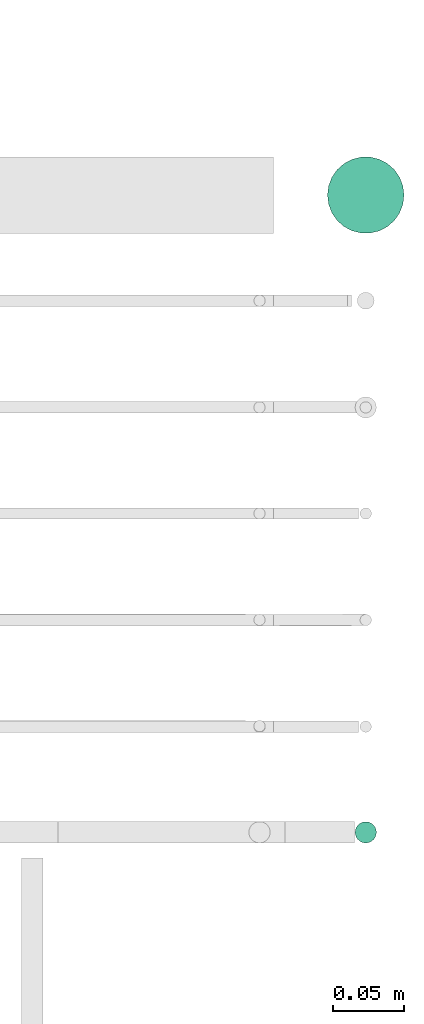
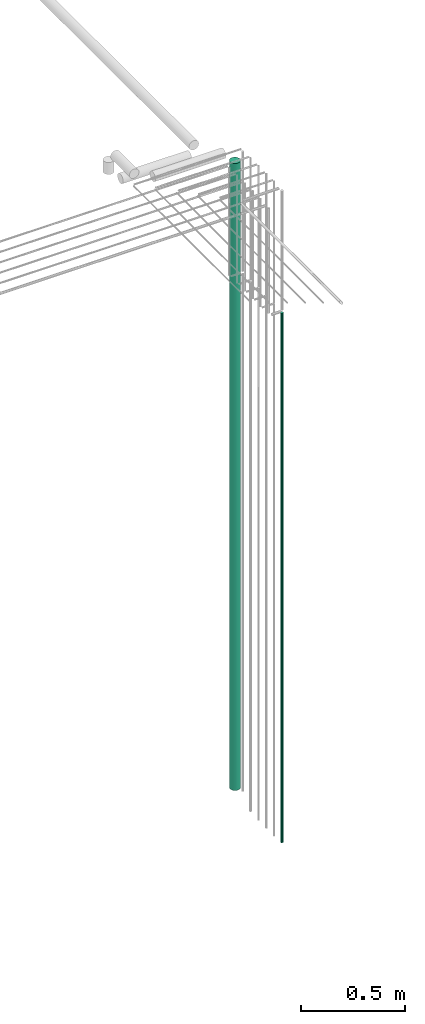
# One storey, part 35 of 89: 2 flow segments.
"""IFC2X3 building model written with IfcOpenShell, lengths in millimetres."""

import ifcopenshell
import ifcopenshell.guid

model = None  # the IFC model being written
_history = None  # IfcOwnerHistory: only IFC2X3 demands one
_inside = {}  # id of a spatial element -> (the spatial element, [elements in it])
_under = {}  # id of a project, library or spatial element -> (it, [spatial elements below it])
_declared = {}  # id of a project -> (the project, [libraries it declares])
_typed = {}  # id of a type object -> (the type object, [elements of that type])
_made_of = {}  # id of a material, layer set ... -> (it, [elements and type objects made of it])


def new_model(schema):
    """Start an empty IFC model of exactly this schema.

    Asked for "IFC4X3", IfcOpenShell would pick the latest addendum, in which some entities
    have other attributes; the version numbers below select the first issue.
    IFC2X3 requires an IfcOwnerHistory on every rooted entity: one is made here for all.
    """
    global model, _history
    if schema == "IFC4X3":
        model = ifcopenshell.file(schema_version=(4, 3, 0, 0))
    else:
        model = ifcopenshell.file(schema=schema)
    _inside.clear()
    _under.clear()
    _declared.clear()
    _typed.clear()
    _made_of.clear()
    _history = None
    if model.schema == "IFC2X3":
        org = make("IfcOrganization", Name="unknown")
        user = make(
            "IfcPersonAndOrganization",
            ThePerson=make("IfcPerson", FamilyName="unknown"),
            TheOrganization=org,
        )
        app = make(
            "IfcApplication",
            ApplicationDeveloper=org,
            Version="unknown",
            ApplicationFullName="unknown",
            ApplicationIdentifier="unknown",
        )
        _history = make(
            "IfcOwnerHistory",
            OwningUser=user,
            OwningApplication=app,
            ChangeAction="ADDED",
            CreationDate=0,
        )
    return model


def make(cls, **values):
    """One entity of the class cls with the attributes given. An attribute that is None is left unset."""
    return model.create_entity(
        cls, **{name: value for name, value in values.items() if value is not None}
    )


def entity(cls, *values):
    """Any entity or typed value of the class cls, its attributes in the order of the schema. None: left unset."""
    e = model.create_entity(cls)
    for i, value in enumerate(values):
        if value is not None:
            e[i] = value
    return e


def rooted(cls, **values):
    """An entity with a GlobalId (a new one), such as an element, a storey or a relation."""
    return make(cls, GlobalId=ifcopenshell.guid.new(), OwnerHistory=_history, **values)


def si_unit(unit_type, name, prefix=None):
    """IfcSIUnit, for example si_unit("LENGTHUNIT", "METRE", prefix="MILLI")."""
    return make("IfcSIUnit", UnitType=unit_type, Prefix=prefix, Name=name)


def converted_unit(unit_type, name, factor, base, dimensions=None, offset=None):
    """IfcConversionBasedUnit, such as the inch: factor (a typed value) times the base unit."""
    return make(
        "IfcConversionBasedUnit"
        if offset is None
        else "IfcConversionBasedUnitWithOffset",
        ConversionOffset=offset,
        Dimensions=None
        if dimensions is None
        else entity("IfcDimensionalExponents", *dimensions),
        UnitType=unit_type,
        Name=name,
        ConversionFactor=make(
            "IfcMeasureWithUnit", ValueComponent=factor, UnitComponent=base
        ),
    )


def derived_unit(unit_type, elements):
    """IfcDerivedUnit: a product of units, each with its exponent."""
    return make(
        "IfcDerivedUnit",
        Elements=[
            make("IfcDerivedUnitElement", Unit=unit, Exponent=power)
            for unit, power in elements
        ],
        UnitType=unit_type,
    )


def assignment(units):
    """IfcUnitAssignment: the units of a project."""
    return None if units is None else make("IfcUnitAssignment", Units=units)


def point(xyz):
    """IfcCartesianPoint."""
    return None if xyz is None else make("IfcCartesianPoint", Coordinates=xyz)


def direction(xyz):
    """IfcDirection."""
    return None if xyz is None else make("IfcDirection", DirectionRatios=xyz)


def frame(location, z_axis=None, x_axis=None):
    """IfcAxis2Placement3D, a coordinate frame: its origin and axes. An axis left out is left unset."""
    return make(
        "IfcAxis2Placement3D",
        Location=point(location),
        Axis=direction(z_axis),
        RefDirection=direction(x_axis),
    )


def frame_2d(location, x_axis=None):
    """IfcAxis2Placement2D, a coordinate frame in the plane: its origin and x axis."""
    return make(
        "IfcAxis2Placement2D", Location=point(location), RefDirection=direction(x_axis)
    )


def origin():
    """The frame at (0, 0, 0) with its axes left unset."""
    return frame((0.0, 0.0, 0.0))


def place(relative_to, where):
    """IfcLocalPlacement: puts the frame where relative to a parent placement (None: the world)."""
    return make(
        "IfcLocalPlacement", PlacementRelTo=relative_to, RelativePlacement=where
    )


def context(
    kind, dimensions, precision=None, world=None, true_north=None, identifier=None
):
    """IfcGeometricRepresentationContext, for example the 3D "Model" context."""
    return make(
        "IfcGeometricRepresentationContext",
        ContextIdentifier=identifier,
        ContextType=kind,
        CoordinateSpaceDimension=dimensions,
        Precision=precision,
        WorldCoordinateSystem=world,
        TrueNorth=true_north,
    )


def subcontext(parent, identifier, kind, view, scale=None):
    """IfcGeometricRepresentationSubContext, for example "Body" below "Model"."""
    return make(
        "IfcGeometricRepresentationSubContext",
        ContextIdentifier=identifier,
        ContextType=kind,
        ParentContext=parent,
        TargetScale=scale,
        TargetView=view,
    )


def project(units=None, contexts=None):
    """IfcProject with its units and contexts."""
    return rooted(
        "IfcProject",
        Name="project",
        RepresentationContexts=contexts,
        UnitsInContext=assignment(units),
    )


def spatial(cls, under=None, at=None, **own):
    """A site, building, storey or space (cls), placed at a placement, below another one or the project."""
    s = rooted(cls, ObjectPlacement=at, **own)
    if under is not None:
        _under.setdefault(under.id(), (under, []))[1].append(s)
    return s


def profile(cls, at=None, kind="AREA", **sizes):
    """A parametric profile (cls). Its sizes go by their IFC names, for example OverallWidth=200.0."""
    return make(cls, ProfileType=kind, Position=at, **sizes)


def circle(**sizes):
    """IfcCircleProfileDef."""
    return profile("IfcCircleProfileDef", **sizes)


def extrude(swept, where, along, depth):
    """IfcExtrudedAreaSolid: the profile swept, set in the frame where, extruded along a direction by depth."""
    return make(
        "IfcExtrudedAreaSolid",
        SweptArea=swept,
        Position=where,
        ExtrudedDirection=direction(along),
        Depth=depth,
    )


def shape(context_of_items, identifier, shape_type, items):
    """IfcShapeRepresentation: the items that make up one representation, for example the "Body"."""
    return make(
        "IfcShapeRepresentation",
        ContextOfItems=context_of_items,
        RepresentationIdentifier=identifier,
        RepresentationType=shape_type,
        Items=items,
    )


def made_of(thing, what):
    """Note that an element or type object is made of a material, layer set ...; save() writes the relation."""
    if what is not None:
        _made_of.setdefault(what.id(), (what, []))[1].append(thing)
    return thing


def type_object(cls, material=None, **own):
    """A type object (cls), such as IfcWallType, which elements share."""
    return made_of(rooted(cls, **own), material)


def element(
    cls,
    number,
    at=None,
    inside=None,
    cuts=None,
    type_object=None,
    material=None,
    context=None,
    identifier="Body",
    shape_type=None,
    held_by="IfcProductDefinitionShape",
    body=None,
    shapes=None,
    **own,
):
    """One element of the class cls, such as IfcWall. Its Tag is "e" and its number.

    at: its placement. inside: the storey or other place that contains it. cuts: it is an
    opening in that element (IfcRelVoidsElement). A single representation is given by context,
    identifier, shape_type and body (its items); several are given by shapes. held_by: the class
    of the entity that holds the representations. save() writes the other relations.
    """
    e = rooted(cls, Tag="e%d" % number, ObjectPlacement=at, **own)
    if body is not None:
        shapes = [shape(context, identifier, shape_type, body)]
    if shapes is not None:
        e.Representation = make(held_by, Representations=shapes)
    if inside is not None:
        _inside.setdefault(inside.id(), (inside, []))[1].append(e)
    if cuts is not None:
        rooted(
            "IfcRelVoidsElement", RelatingBuildingElement=cuts, RelatedOpeningElement=e
        )
    if type_object is not None:
        _typed.setdefault(type_object.id(), (type_object, []))[1].append(e)
    return made_of(e, material)


def aggregate(whole, parts):
    """IfcRelAggregates: a whole, such as a stair, and the parts it consists of."""
    return rooted("IfcRelAggregates", RelatingObject=whole, RelatedObjects=parts)


def save(model, path):
    """Write the relations noted so far, then the file.

    IfcRelAggregates (storeys below a building ...), IfcRelContainedInSpatialStructure (elements
    in a storey), IfcRelDefinesByType, IfcRelAssociatesMaterial and IfcRelDeclares: one each for
    every whole, place, type object, material and project.
    """
    for whole, parts in _under.values():
        aggregate(whole, parts)
    for where, things in _inside.values():
        rooted(
            "IfcRelContainedInSpatialStructure",
            RelatedElements=things,
            RelatingStructure=where,
        )
    for kind, things in _typed.values():
        rooted("IfcRelDefinesByType", RelatedObjects=things, RelatingType=kind)
    for what, things in _made_of.values():
        rooted("IfcRelAssociatesMaterial", RelatedObjects=things, RelatingMaterial=what)
    for by, libraries in _declared.values():
        rooted("IfcRelDeclares", RelatingContext=by, RelatedDefinitions=libraries)
    model.write(path)


model = new_model("IFC2X3")

# Units and contexts
model_context = context("Model", 3, precision=0.01, world=origin(), true_north=direction((6.12303176911189e-17, 1.0)))
body_context = subcontext(model_context, "Body", "Model", "MODEL_VIEW")
ifc_project = project(units=[si_unit("LENGTHUNIT", "METRE", prefix="MILLI"), si_unit("AREAUNIT", "SQUARE_METRE"), si_unit("VOLUMEUNIT", "CUBIC_METRE"), converted_unit("PLANEANGLEUNIT", "DEGREE", entity("IfcRatioMeasure", 0.0174532925199433), si_unit("PLANEANGLEUNIT", "RADIAN"), dimensions=[0, 0, 0, 0, 0, 0, 0]), si_unit("MASSUNIT", "GRAM", prefix="KILO"), derived_unit("MASSDENSITYUNIT", [(si_unit("MASSUNIT", "GRAM", prefix="KILO"), 1), (si_unit("LENGTHUNIT", "METRE"), -3)]), derived_unit("MOMENTOFINERTIAUNIT", [(si_unit("LENGTHUNIT", "METRE"), 4)]), si_unit("TIMEUNIT", "SECOND"), si_unit("FREQUENCYUNIT", "HERTZ"), si_unit("THERMODYNAMICTEMPERATUREUNIT", "DEGREE_CELSIUS"), derived_unit("THERMALTRANSMITTANCEUNIT", [(si_unit("MASSUNIT", "GRAM", prefix="KILO"), 1), (si_unit("THERMODYNAMICTEMPERATUREUNIT", "KELVIN"), -1), (si_unit("TIMEUNIT", "SECOND"), -3)]), derived_unit("VOLUMETRICFLOWRATEUNIT", [(si_unit("LENGTHUNIT", "METRE"), 3), (si_unit("TIMEUNIT", "SECOND"), -1)]), derived_unit("MASSFLOWRATEUNIT", [(si_unit("MASSUNIT", "GRAM", prefix="KILO"), 1), (si_unit("TIMEUNIT", "SECOND"), -1)]), derived_unit("ROTATIONALFREQUENCYUNIT", [(si_unit("TIMEUNIT", "SECOND"), -1)]), si_unit("ELECTRICCURRENTUNIT", "AMPERE"), si_unit("ELECTRICVOLTAGEUNIT", "VOLT"), si_unit("POWERUNIT", "WATT"), si_unit("FORCEUNIT", "NEWTON", prefix="KILO"), si_unit("ILLUMINANCEUNIT", "LUX"), si_unit("LUMINOUSFLUXUNIT", "LUMEN"), si_unit("LUMINOUSINTENSITYUNIT", "CANDELA"), derived_unit("USERDEFINED", [(si_unit("MASSUNIT", "GRAM", prefix="KILO"), -1), (si_unit("LENGTHUNIT", "METRE"), -2), (si_unit("TIMEUNIT", "SECOND"), 3), (si_unit("LUMINOUSFLUXUNIT", "LUMEN"), 1)]), derived_unit("LINEARVELOCITYUNIT", [(si_unit("LENGTHUNIT", "METRE"), 1), (si_unit("TIMEUNIT", "SECOND"), -1)]), si_unit("PRESSUREUNIT", "PASCAL"), derived_unit("USERDEFINED", [(si_unit("LENGTHUNIT", "METRE"), -2), (si_unit("MASSUNIT", "GRAM", prefix="KILO"), 1), (si_unit("TIMEUNIT", "SECOND"), -2)]), derived_unit("LINEARFORCEUNIT", [(si_unit("MASSUNIT", "GRAM", prefix="KILO"), 1), (si_unit("LENGTHUNIT", "METRE"), 1), (si_unit("TIMEUNIT", "SECOND"), -2), (si_unit("LENGTHUNIT", "METRE"), -1)]), derived_unit("PLANARFORCEUNIT", [(si_unit("MASSUNIT", "GRAM", prefix="KILO"), 1), (si_unit("LENGTHUNIT", "METRE"), 1), (si_unit("TIMEUNIT", "SECOND"), -2), (si_unit("LENGTHUNIT", "METRE"), -2)])], contexts=[model_context])

# Site, building, storey
site_placement = place(None, frame((0.0, -0.00077364408347762, 0.0)))
site = spatial("IfcSite", under=ifc_project, at=site_placement, CompositionType="ELEMENT")
building_placement = place(site_placement, origin())
building = spatial("IfcBuilding", under=site, at=building_placement, CompositionType="ELEMENT")
storey_placement = place(building_placement, frame((0.0, 0.0, 24000.0)))
storey = spatial("IfcBuildingStorey", under=building, at=storey_placement, CompositionType="ELEMENT", Elevation=24000.0)

# Flow segments
pipe_segment_type = type_object("IfcPipeSegmentType", PredefinedType="NOTDEFINED")
flow_segment_1_placement = place(storey_placement, frame((73297.6022607087, 10350.7754696782, -1132.0)))
element("IfcFlowSegment", 1, at=flow_segment_1_placement, inside=storey, type_object=pipe_segment_type, context=body_context, shape_type="SweptSolid", body=[
    extrude(circle(Radius=7.5, at=frame_2d((0.0, -2.16573425859679e-12), x_axis=(1.0, 0.0))), frame((9.09527223591419, 9.09527223591853, 0.0)), (0.0, 0.0, 1.0), 3099.00000000001),
])
flow_segment_2_placement = place(storey_placement, frame((73278.1022607087, 10781.1546458955, -1085.0)))
element("IfcFlowSegment", 2, at=flow_segment_2_placement, inside=storey, type_object=pipe_segment_type, context=body_context, shape_type="SweptSolid", body=[
    extrude(circle(Radius=27.0, at=frame_2d((8.66293703438714e-12, 0.0), x_axis=(1.0, 0.0))), frame((28.5952722359098, 28.5952722359163, 0.0)), (0.0, 0.0, 1.0), 3669.96470800251),
])

save(model, "model.ifc")
